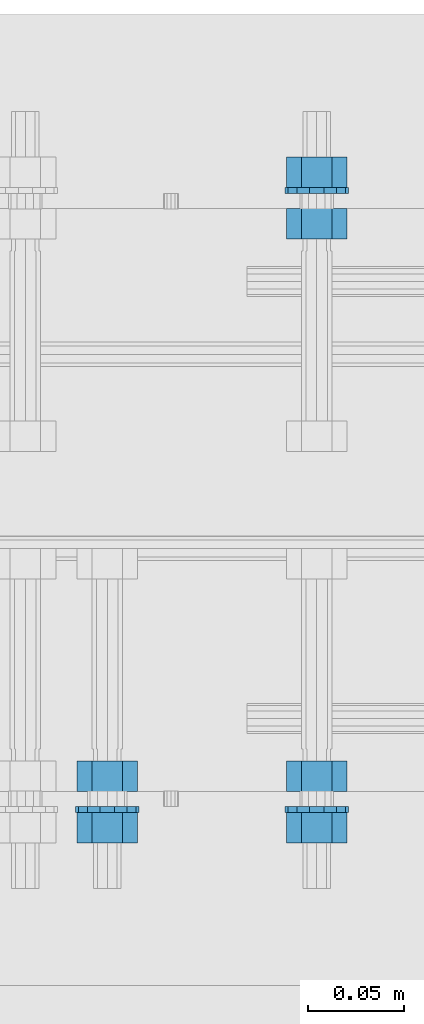
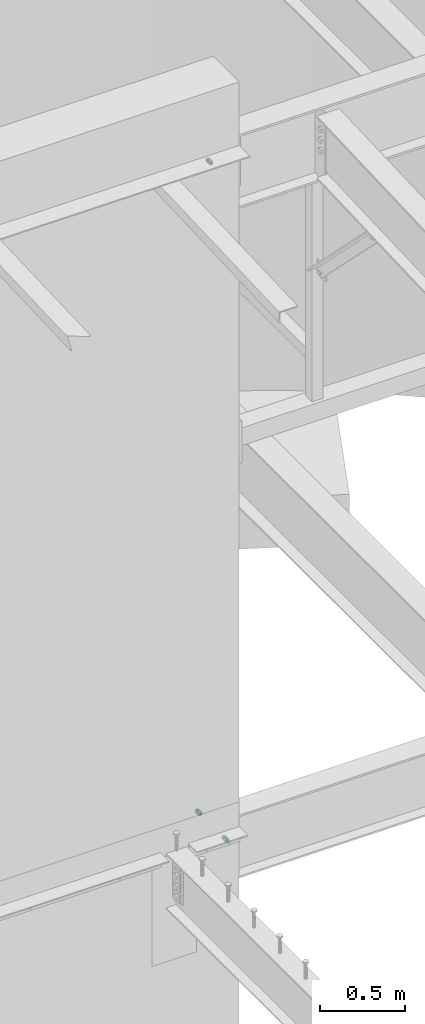
# One storey, part 626 of 975: 9 beams.
"""IFC2X3 building model written with IfcOpenShell, lengths in millimetres."""

from ifc_helpers import new_model, si_unit, frame, origin_with_axes, place, context, subcontext, project, spatial, faceted_brep, material, type_object, element, save


model = new_model("IFC2X3")

# Units and contexts
model_context = context("Model", 3, precision=1e-05, world=origin_with_axes())
body_context = subcontext(model_context, "Body", "Model", "MODEL_VIEW")
ifc_project = project(units=[si_unit("LENGTHUNIT", "METRE", prefix="MILLI"), si_unit("AREAUNIT", "SQUARE_METRE"), si_unit("VOLUMEUNIT", "CUBIC_METRE"), si_unit("MASSUNIT", "GRAM", prefix="KILO"), si_unit("TIMEUNIT", "SECOND"), si_unit("PLANEANGLEUNIT", "RADIAN"), si_unit("SOLIDANGLEUNIT", "STERADIAN"), si_unit("THERMODYNAMICTEMPERATUREUNIT", "DEGREE_CELSIUS"), si_unit("LUMINOUSINTENSITYUNIT", "LUMEN")], contexts=[model_context])

# Site, building, storey
site_placement = place(None, origin_with_axes())
site = spatial("IfcSite", under=ifc_project, at=site_placement, CompositionType="ELEMENT")
building_placement = place(site_placement, origin_with_axes())
building = spatial("IfcBuilding", under=site, at=building_placement, Name="Undefined", CompositionType="ELEMENT")
storey_placement = place(building_placement, origin_with_axes())
storey = spatial("IfcBuildingStorey", under=building, at=storey_placement, Name="Undefined", CompositionType="ELEMENT", Elevation=0.0)

# Beams
ifc_material_1 = material(Name="STEEL/F1554-36")
beam_type_1 = type_object("IfcBeamType", Name="5/8_HEAVY_HEX_NUT", PredefinedType="NOTDEFINED")
beam_1_placement = place(storey_placement, frame((13722.3499940823, 20443.8249990482, 8801.10000023449), z_axis=(0.0, 0.0, 1.0), x_axis=(0.0, 1.0, 0.0)))
element("IfcBeam", 1, at=beam_1_placement, inside=storey, type_object=beam_type_1, material=ifc_material_1, Name="HEADED_ANCHOR_BOLT", ObjectType="5/8_HEAVY_HEX_NUT", context=body_context, shape_type="Brep", body=[
    faceted_brep([(-1.09139364212751e-11, -15.8800001144436, -2.72848410531878e-12), (1.45519152283669e-11, -7.94000005722046, -13.7500000000036), (15.8750000000146, -7.94000005722137, -13.7500000000045), (15.8749999999891, -15.8800001144446, -2.72848410531878e-12), (2.91038304567337e-11, 7.94000005722319, -13.7500000000027), (15.8750000000291, 7.94000005722319, -13.7500000000027), (2.18278728425503e-11, 15.8800001144436, 9.09494701772928e-13), (15.8750000000218, 15.8800001144427, 9.09494701772928e-13), (-7.27595761418343e-12, 7.94000005722046, 13.7500000000027), (15.8749999999927, 7.94000005722046, 13.7500000000027), (-2.18278728425503e-11, -7.94000005722228, 13.7500000000009), (15.8749999999782, -7.94000005722319, 13.7500000000009), (-7.27595761418343e-12, 0.0, 8.72999954223724), (0.0, 3.78780484388062, 7.86545780435881), (15.875, 3.78780484387971, 7.86545780435881), (15.8749999999927, -9.09494701772928e-13, 8.72999954223724), (7.27595761418343e-12, 6.82538848405238, 5.44306568481716), (15.8750000000073, 6.82538848405238, 5.44306568481716), (1.09139364212751e-11, 8.51112022706275, 1.94260765157742), (15.8750000000109, 8.51112022706093, 1.94260765157651), (1.45519152283669e-11, 8.51112022706184, -1.94260765157651), (15.8750000000146, 8.51112022706184, -1.94260765157651), (2.18278728425503e-11, 6.8253884840542, -5.44306568481716), (15.8750000000218, 6.82538848405238, -5.44306568481716), (1.81898940354586e-11, 3.78780484388153, -7.86545780435881), (15.8750000000182, 3.78780484388062, -7.86545780435881), (1.81898940354586e-11, 9.09494701772928e-13, -8.72999954223997), (15.8750000000182, 9.09494701772928e-13, -8.72999954223997), (1.09139364212751e-11, -3.78780484387971, -7.86545780436063), (15.8750000000109, -3.78780484388062, -7.86545780436063), (3.63797880709171e-12, -6.82538848405238, -5.44306568481807), (15.8750000000036, -6.82538848405329, -5.44306568481807), (0.0, -8.51112022706184, -1.94260765157833), (15.875, -8.51112022706184, -1.94260765157833), (-7.27595761418343e-12, -8.51112022706184, 1.9426076515756), (15.8749999999927, -8.51112022706275, 1.9426076515756), (-1.09139364212751e-11, -6.82538848405329, 5.44306568481534), (15.8749999999927, -6.8253884840542, 5.44306568481534), (-7.27595761418343e-12, -3.78780484388062, 7.8654578043579), (15.8749999999927, -3.78780484388153, 7.8654578043579)], [[[0, 1, 2, 3]], [[1, 4, 5, 2]], [[4, 6, 7, 5]], [[6, 8, 9, 7]], [[8, 10, 11, 9]], [[10, 0, 3, 11]], [[12, 13, 14, 15]], [[13, 16, 17, 14]], [[16, 18, 19, 17]], [[18, 20, 21, 19]], [[20, 22, 23, 21]], [[22, 24, 25, 23]], [[24, 26, 27, 25]], [[26, 28, 29, 27]], [[28, 30, 31, 29]], [[30, 32, 33, 31]], [[32, 34, 35, 33]], [[34, 36, 37, 35]], [[36, 38, 39, 37]], [[38, 12, 15, 39]], [[5, 7, 9, 11, 3, 2], [17, 19, 21, 23, 25, 27, 29, 31, 33, 35, 37, 39, 15, 14]], [[10, 8, 6, 4, 1, 0], [38, 36, 34, 32, 30, 28, 26, 24, 22, 20, 18, 16, 13, 12]]]),
])
beam_2_placement = place(storey_placement, frame((13722.3499966058, 20416.8374990479, 8801.10000017628), z_axis=(0.0, 0.0, 1.0), x_axis=(0.0, 1.0, 0.0)))
element("IfcBeam", 2, at=beam_2_placement, inside=storey, type_object=beam_type_1, material=ifc_material_1, Name="HEADED_ANCHOR_BOLT", ObjectType="5/8_HEAVY_HEX_NUT", context=body_context, shape_type="Brep", body=[
    faceted_brep([(-1.09139364212751e-11, -15.8800001144436, -2.72848410531878e-12), (1.45519152283669e-11, -7.94000005722046, -13.7500000000036), (15.8750000000146, -7.94000005722137, -13.7500000000045), (15.8749999999891, -15.8800001144446, -2.72848410531878e-12), (2.91038304567337e-11, 7.94000005722319, -13.7500000000027), (15.8750000000291, 7.94000005722319, -13.7500000000027), (2.18278728425503e-11, 15.8800001144436, 9.09494701772928e-13), (15.8750000000218, 15.8800001144427, 9.09494701772928e-13), (-7.27595761418343e-12, 7.94000005722046, 13.7500000000027), (15.8749999999927, 7.94000005722046, 13.7500000000027), (-2.18278728425503e-11, -7.94000005722228, 13.7500000000009), (15.8749999999782, -7.94000005722319, 13.7500000000009), (-7.27595761418343e-12, 0.0, 8.72999954223724), (0.0, 3.78780484388062, 7.86545780435881), (15.875, 3.78780484387971, 7.86545780435881), (15.8749999999927, -9.09494701772928e-13, 8.72999954223724), (7.27595761418343e-12, 6.82538848405238, 5.44306568481716), (15.8750000000073, 6.82538848405238, 5.44306568481716), (1.09139364212751e-11, 8.51112022706275, 1.94260765157742), (15.8750000000109, 8.51112022706093, 1.94260765157651), (1.45519152283669e-11, 8.51112022706184, -1.94260765157651), (15.8750000000146, 8.51112022706184, -1.94260765157651), (2.18278728425503e-11, 6.8253884840542, -5.44306568481716), (15.8750000000218, 6.82538848405238, -5.44306568481716), (1.81898940354586e-11, 3.78780484388153, -7.86545780435881), (15.8750000000182, 3.78780484388062, -7.86545780435881), (1.81898940354586e-11, 9.09494701772928e-13, -8.72999954223997), (15.8750000000182, 9.09494701772928e-13, -8.72999954223997), (1.09139364212751e-11, -3.78780484387971, -7.86545780436063), (15.8750000000109, -3.78780484388062, -7.86545780436063), (3.63797880709171e-12, -6.82538848405238, -5.44306568481807), (15.8750000000036, -6.82538848405329, -5.44306568481807), (0.0, -8.51112022706184, -1.94260765157833), (15.875, -8.51112022706184, -1.94260765157833), (-7.27595761418343e-12, -8.51112022706184, 1.9426076515756), (15.8749999999927, -8.51112022706275, 1.9426076515756), (-1.09139364212751e-11, -6.82538848405329, 5.44306568481534), (15.8749999999927, -6.8253884840542, 5.44306568481534), (-7.27595761418343e-12, -3.78780484388062, 7.8654578043579), (15.8749999999927, -3.78780484388153, 7.8654578043579)], [[[0, 1, 2, 3]], [[1, 4, 5, 2]], [[4, 6, 7, 5]], [[6, 8, 9, 7]], [[8, 10, 11, 9]], [[10, 0, 3, 11]], [[12, 13, 14, 15]], [[13, 16, 17, 14]], [[16, 18, 19, 17]], [[18, 20, 21, 19]], [[20, 22, 23, 21]], [[22, 24, 25, 23]], [[24, 26, 27, 25]], [[26, 28, 29, 27]], [[28, 30, 31, 29]], [[30, 32, 33, 31]], [[32, 34, 35, 33]], [[34, 36, 37, 35]], [[36, 38, 39, 37]], [[38, 12, 15, 39]], [[5, 7, 9, 11, 3, 2], [17, 19, 21, 23, 25, 27, 29, 31, 33, 35, 37, 39, 15, 14]], [[10, 8, 6, 4, 1, 0], [38, 36, 34, 32, 30, 28, 26, 24, 22, 20, 18, 16, 13, 12]]]),
])
ifc_material_2 = material(Name="STEEL/A36")
beam_3_placement = place(storey_placement, frame((13831.8874969437, 20748.6249997605, 3886.2), z_axis=(0.0, 0.0, -1.0), x_axis=(0.0, -1.0, 0.0)))
element("IfcBeam", 3, at=beam_3_placement, inside=storey, type_object=beam_type_1, material=ifc_material_2, Name="NUT", ObjectType="5/8_HEAVY_HEX_NUT", context=body_context, shape_type="Brep", body=[
    faceted_brep([(-1.09139364212751e-11, -15.8800001144436, -2.72848410531878e-12), (1.45519152283669e-11, -7.94000005722046, -13.7500000000036), (15.8750000000146, -7.94000005722137, -13.7500000000045), (15.8749999999891, -15.8800001144446, -2.72848410531878e-12), (2.91038304567337e-11, 7.94000005722319, -13.7500000000027), (15.8750000000291, 7.94000005722319, -13.7500000000027), (2.18278728425503e-11, 15.8800001144436, 9.09494701772928e-13), (15.8750000000218, 15.8800001144427, 9.09494701772928e-13), (-7.27595761418343e-12, 7.94000005722046, 13.7500000000027), (15.8749999999927, 7.94000005722046, 13.7500000000027), (-2.18278728425503e-11, -7.94000005722228, 13.7500000000009), (15.8749999999782, -7.94000005722319, 13.7500000000009), (-7.27595761418343e-12, 0.0, 8.72999954223724), (0.0, 3.78780484388062, 7.86545780435881), (15.875, 3.78780484387971, 7.86545780435881), (15.8749999999927, -9.09494701772928e-13, 8.72999954223724), (7.27595761418343e-12, 6.82538848405238, 5.44306568481716), (15.8750000000073, 6.82538848405238, 5.44306568481716), (1.09139364212751e-11, 8.51112022706275, 1.94260765157742), (15.8750000000109, 8.51112022706093, 1.94260765157651), (1.45519152283669e-11, 8.51112022706184, -1.94260765157651), (15.8750000000146, 8.51112022706184, -1.94260765157651), (2.18278728425503e-11, 6.8253884840542, -5.44306568481716), (15.8750000000218, 6.82538848405238, -5.44306568481716), (1.81898940354586e-11, 3.78780484388153, -7.86545780435881), (15.8750000000182, 3.78780484388062, -7.86545780435881), (1.81898940354586e-11, 9.09494701772928e-13, -8.72999954223997), (15.8750000000182, 9.09494701772928e-13, -8.72999954223997), (1.09139364212751e-11, -3.78780484387971, -7.86545780436063), (15.8750000000109, -3.78780484388062, -7.86545780436063), (3.63797880709171e-12, -6.82538848405238, -5.44306568481807), (15.8750000000036, -6.82538848405329, -5.44306568481807), (0.0, -8.51112022706184, -1.94260765157833), (15.875, -8.51112022706184, -1.94260765157833), (-7.27595761418343e-12, -8.51112022706184, 1.9426076515756), (15.8749999999927, -8.51112022706275, 1.9426076515756), (-1.09139364212751e-11, -6.82538848405329, 5.44306568481534), (15.8749999999927, -6.8253884840542, 5.44306568481534), (-7.27595761418343e-12, -3.78780484388062, 7.8654578043579), (15.8749999999927, -3.78780484388153, 7.8654578043579)], [[[0, 1, 2, 3]], [[1, 4, 5, 2]], [[4, 6, 7, 5]], [[6, 8, 9, 7]], [[8, 10, 11, 9]], [[10, 0, 3, 11]], [[12, 13, 14, 15]], [[13, 16, 17, 14]], [[16, 18, 19, 17]], [[18, 20, 21, 19]], [[20, 22, 23, 21]], [[22, 24, 25, 23]], [[24, 26, 27, 25]], [[26, 28, 29, 27]], [[28, 30, 31, 29]], [[30, 32, 33, 31]], [[32, 34, 35, 33]], [[34, 36, 37, 35]], [[36, 38, 39, 37]], [[38, 12, 15, 39]], [[5, 7, 9, 11, 3, 2], [17, 19, 21, 23, 25, 27, 29, 31, 33, 35, 37, 39, 15, 14]], [[10, 8, 6, 4, 1, 0], [38, 36, 34, 32, 30, 28, 26, 24, 22, 20, 18, 16, 13, 12]]]),
])
beam_4_placement = place(storey_placement, frame((13831.8874969437, 20443.8250002493, 3886.2), z_axis=(0.0, 0.0, 1.0), x_axis=(0.0, 1.0, 0.0)))
element("IfcBeam", 4, at=beam_4_placement, inside=storey, type_object=beam_type_1, material=ifc_material_2, Name="NUT", ObjectType="5/8_HEAVY_HEX_NUT", context=body_context, shape_type="Brep", body=[
    faceted_brep([(-1.09139364212751e-11, -15.8800001144436, -2.72848410531878e-12), (1.45519152283669e-11, -7.94000005722046, -13.7500000000036), (15.8750000000146, -7.94000005722137, -13.7500000000045), (15.8749999999891, -15.8800001144446, -2.72848410531878e-12), (2.91038304567337e-11, 7.94000005722319, -13.7500000000027), (15.8750000000291, 7.94000005722319, -13.7500000000027), (2.18278728425503e-11, 15.8800001144436, 9.09494701772928e-13), (15.8750000000218, 15.8800001144427, 9.09494701772928e-13), (-7.27595761418343e-12, 7.94000005722046, 13.7500000000027), (15.8749999999927, 7.94000005722046, 13.7500000000027), (-2.18278728425503e-11, -7.94000005722228, 13.7500000000009), (15.8749999999782, -7.94000005722319, 13.7500000000009), (-7.27595761418343e-12, 0.0, 8.72999954223724), (0.0, 3.78780484388062, 7.86545780435881), (15.875, 3.78780484387971, 7.86545780435881), (15.8749999999927, -9.09494701772928e-13, 8.72999954223724), (7.27595761418343e-12, 6.82538848405238, 5.44306568481716), (15.8750000000073, 6.82538848405238, 5.44306568481716), (1.09139364212751e-11, 8.51112022706275, 1.94260765157742), (15.8750000000109, 8.51112022706093, 1.94260765157651), (1.45519152283669e-11, 8.51112022706184, -1.94260765157651), (15.8750000000146, 8.51112022706184, -1.94260765157651), (2.18278728425503e-11, 6.8253884840542, -5.44306568481716), (15.8750000000218, 6.82538848405238, -5.44306568481716), (1.81898940354586e-11, 3.78780484388153, -7.86545780435881), (15.8750000000182, 3.78780484388062, -7.86545780435881), (1.81898940354586e-11, 9.09494701772928e-13, -8.72999954223997), (15.8750000000182, 9.09494701772928e-13, -8.72999954223997), (1.09139364212751e-11, -3.78780484387971, -7.86545780436063), (15.8750000000109, -3.78780484388062, -7.86545780436063), (3.63797880709171e-12, -6.82538848405238, -5.44306568481807), (15.8750000000036, -6.82538848405329, -5.44306568481807), (0.0, -8.51112022706184, -1.94260765157833), (15.875, -8.51112022706184, -1.94260765157833), (-7.27595761418343e-12, -8.51112022706184, 1.9426076515756), (15.8749999999927, -8.51112022706275, 1.9426076515756), (-1.09139364212751e-11, -6.82538848405329, 5.44306568481534), (15.8749999999927, -6.8253884840542, 5.44306568481534), (-7.27595761418343e-12, -3.78780484388062, 7.8654578043579), (15.8749999999927, -3.78780484388153, 7.8654578043579)], [[[0, 1, 2, 3]], [[1, 4, 5, 2]], [[4, 6, 7, 5]], [[6, 8, 9, 7]], [[8, 10, 11, 9]], [[10, 0, 3, 11]], [[12, 13, 14, 15]], [[13, 16, 17, 14]], [[16, 18, 19, 17]], [[18, 20, 21, 19]], [[20, 22, 23, 21]], [[22, 24, 25, 23]], [[24, 26, 27, 25]], [[26, 28, 29, 27]], [[28, 30, 31, 29]], [[30, 32, 33, 31]], [[32, 34, 35, 33]], [[34, 36, 37, 35]], [[36, 38, 39, 37]], [[38, 12, 15, 39]], [[5, 7, 9, 11, 3, 2], [17, 19, 21, 23, 25, 27, 29, 31, 33, 35, 37, 39, 15, 14]], [[10, 8, 6, 4, 1, 0], [38, 36, 34, 32, 30, 28, 26, 24, 22, 20, 18, 16, 13, 12]]]),
])
beam_5_placement = place(storey_placement, frame((13831.8874969706, 20775.6124997508, 3886.2), z_axis=(0.0, 0.0, -1.0), x_axis=(0.0, -1.0, 0.0)))
element("IfcBeam", 5, at=beam_5_placement, inside=storey, type_object=beam_type_1, material=ifc_material_2, Name="NUT", ObjectType="5/8_HEAVY_HEX_NUT", context=body_context, shape_type="Brep", body=[
    faceted_brep([(-1.09139364212751e-11, -15.8800001144436, -2.72848410531878e-12), (1.45519152283669e-11, -7.94000005722046, -13.7500000000036), (15.8750000000146, -7.94000005722137, -13.7500000000045), (15.8749999999891, -15.8800001144446, -2.72848410531878e-12), (2.91038304567337e-11, 7.94000005722319, -13.7500000000027), (15.8750000000291, 7.94000005722319, -13.7500000000027), (2.18278728425503e-11, 15.8800001144436, 9.09494701772928e-13), (15.8750000000218, 15.8800001144427, 9.09494701772928e-13), (-7.27595761418343e-12, 7.94000005722046, 13.7500000000027), (15.8749999999927, 7.94000005722046, 13.7500000000027), (-2.18278728425503e-11, -7.94000005722228, 13.7500000000009), (15.8749999999782, -7.94000005722319, 13.7500000000009), (-7.27595761418343e-12, 0.0, 8.72999954223724), (0.0, 3.78780484388062, 7.86545780435881), (15.875, 3.78780484387971, 7.86545780435881), (15.8749999999927, -9.09494701772928e-13, 8.72999954223724), (7.27595761418343e-12, 6.82538848405238, 5.44306568481716), (15.8750000000073, 6.82538848405238, 5.44306568481716), (1.09139364212751e-11, 8.51112022706275, 1.94260765157742), (15.8750000000109, 8.51112022706093, 1.94260765157651), (1.45519152283669e-11, 8.51112022706184, -1.94260765157651), (15.8750000000146, 8.51112022706184, -1.94260765157651), (2.18278728425503e-11, 6.8253884840542, -5.44306568481716), (15.8750000000218, 6.82538848405238, -5.44306568481716), (1.81898940354586e-11, 3.78780484388153, -7.86545780435881), (15.8750000000182, 3.78780484388062, -7.86545780435881), (1.81898940354586e-11, 9.09494701772928e-13, -8.72999954223997), (15.8750000000182, 9.09494701772928e-13, -8.72999954223997), (1.09139364212751e-11, -3.78780484387971, -7.86545780436063), (15.8750000000109, -3.78780484388062, -7.86545780436063), (3.63797880709171e-12, -6.82538848405238, -5.44306568481807), (15.8750000000036, -6.82538848405329, -5.44306568481807), (0.0, -8.51112022706184, -1.94260765157833), (15.875, -8.51112022706184, -1.94260765157833), (-7.27595761418343e-12, -8.51112022706184, 1.9426076515756), (15.8749999999927, -8.51112022706275, 1.9426076515756), (-1.09139364212751e-11, -6.82538848405329, 5.44306568481534), (15.8749999999927, -6.8253884840542, 5.44306568481534), (-7.27595761418343e-12, -3.78780484388062, 7.8654578043579), (15.8749999999927, -3.78780484388153, 7.8654578043579)], [[[0, 1, 2, 3]], [[1, 4, 5, 2]], [[4, 6, 7, 5]], [[6, 8, 9, 7]], [[8, 10, 11, 9]], [[10, 0, 3, 11]], [[12, 13, 14, 15]], [[13, 16, 17, 14]], [[16, 18, 19, 17]], [[18, 20, 21, 19]], [[20, 22, 23, 21]], [[22, 24, 25, 23]], [[24, 26, 27, 25]], [[26, 28, 29, 27]], [[28, 30, 31, 29]], [[30, 32, 33, 31]], [[32, 34, 35, 33]], [[34, 36, 37, 35]], [[36, 38, 39, 37]], [[38, 12, 15, 39]], [[5, 7, 9, 11, 3, 2], [17, 19, 21, 23, 25, 27, 29, 31, 33, 35, 37, 39, 15, 14]], [[10, 8, 6, 4, 1, 0], [38, 36, 34, 32, 30, 28, 26, 24, 22, 20, 18, 16, 13, 12]]]),
])
beam_6_placement = place(storey_placement, frame((13831.8874969706, 20416.8375002493, 3886.2), z_axis=(0.0, 0.0, 1.0), x_axis=(0.0, 1.0, 0.0)))
element("IfcBeam", 6, at=beam_6_placement, inside=storey, type_object=beam_type_1, material=ifc_material_2, Name="NUT", ObjectType="5/8_HEAVY_HEX_NUT", context=body_context, shape_type="Brep", body=[
    faceted_brep([(-1.09139364212751e-11, -15.8800001144436, -2.72848410531878e-12), (1.45519152283669e-11, -7.94000005722046, -13.7500000000036), (15.8750000000146, -7.94000005722137, -13.7500000000045), (15.8749999999891, -15.8800001144446, -2.72848410531878e-12), (2.91038304567337e-11, 7.94000005722319, -13.7500000000027), (15.8750000000291, 7.94000005722319, -13.7500000000027), (2.18278728425503e-11, 15.8800001144436, 9.09494701772928e-13), (15.8750000000218, 15.8800001144427, 9.09494701772928e-13), (-7.27595761418343e-12, 7.94000005722046, 13.7500000000027), (15.8749999999927, 7.94000005722046, 13.7500000000027), (-2.18278728425503e-11, -7.94000005722228, 13.7500000000009), (15.8749999999782, -7.94000005722319, 13.7500000000009), (-7.27595761418343e-12, 0.0, 8.72999954223724), (0.0, 3.78780484388062, 7.86545780435881), (15.875, 3.78780484387971, 7.86545780435881), (15.8749999999927, -9.09494701772928e-13, 8.72999954223724), (7.27595761418343e-12, 6.82538848405238, 5.44306568481716), (15.8750000000073, 6.82538848405238, 5.44306568481716), (1.09139364212751e-11, 8.51112022706275, 1.94260765157742), (15.8750000000109, 8.51112022706093, 1.94260765157651), (1.45519152283669e-11, 8.51112022706184, -1.94260765157651), (15.8750000000146, 8.51112022706184, -1.94260765157651), (2.18278728425503e-11, 6.8253884840542, -5.44306568481716), (15.8750000000218, 6.82538848405238, -5.44306568481716), (1.81898940354586e-11, 3.78780484388153, -7.86545780435881), (15.8750000000182, 3.78780484388062, -7.86545780435881), (1.81898940354586e-11, 9.09494701772928e-13, -8.72999954223997), (15.8750000000182, 9.09494701772928e-13, -8.72999954223997), (1.09139364212751e-11, -3.78780484387971, -7.86545780436063), (15.8750000000109, -3.78780484388062, -7.86545780436063), (3.63797880709171e-12, -6.82538848405238, -5.44306568481807), (15.8750000000036, -6.82538848405329, -5.44306568481807), (0.0, -8.51112022706184, -1.94260765157833), (15.875, -8.51112022706184, -1.94260765157833), (-7.27595761418343e-12, -8.51112022706184, 1.9426076515756), (15.8749999999927, -8.51112022706275, 1.9426076515756), (-1.09139364212751e-11, -6.82538848405329, 5.44306568481534), (15.8749999999927, -6.8253884840542, 5.44306568481534), (-7.27595761418343e-12, -3.78780484388062, 7.8654578043579), (15.8749999999927, -3.78780484388153, 7.8654578043579)], [[[0, 1, 2, 3]], [[1, 4, 5, 2]], [[4, 6, 7, 5]], [[6, 8, 9, 7]], [[8, 10, 11, 9]], [[10, 0, 3, 11]], [[12, 13, 14, 15]], [[13, 16, 17, 14]], [[16, 18, 19, 17]], [[18, 20, 21, 19]], [[20, 22, 23, 21]], [[22, 24, 25, 23]], [[24, 26, 27, 25]], [[26, 28, 29, 27]], [[28, 30, 31, 29]], [[30, 32, 33, 31]], [[32, 34, 35, 33]], [[34, 36, 37, 35]], [[36, 38, 39, 37]], [[38, 12, 15, 39]], [[5, 7, 9, 11, 3, 2], [17, 19, 21, 23, 25, 27, 29, 31, 33, 35, 37, 39, 15, 14]], [[10, 8, 6, 4, 1, 0], [38, 36, 34, 32, 30, 28, 26, 24, 22, 20, 18, 16, 13, 12]]]),
])
beam_type_2 = type_object("IfcBeamType", Name="5/8_WASHER", PredefinedType="NOTDEFINED")
beam_7_placement = place(storey_placement, frame((13722.3499950685, 20432.7124990477, 8801.10000026254), z_axis=(0.0, 0.0, 1.0), x_axis=(0.0, 1.0, 0.0)))
element("IfcBeam", 7, at=beam_7_placement, inside=storey, type_object=beam_type_2, material=ifc_material_1, Name="HEADED_ANCHOR_BOLT", ObjectType="5/8_WASHER", context=body_context, shape_type="Brep", body=[
    faceted_brep([(1.09139364212751e-11, -16.670000076293, -2.72848410531878e-12), (2.18278728425503e-11, -15.0191510966704, -7.23284196419536), (3.1750000000211, -15.0191510966711, -7.23284196419627), (3.17500000001019, -16.6700000762937, -1.81898940354586e-12), (2.91038304567337e-11, -10.3935750445523, -13.0331308723944), (3.17500000002838, -10.3935750445526, -13.0331308723953), (2.91038304567337e-11, -3.70942398602756, -16.2520483704566), (3.17500000002838, -3.70942398602779, -16.2520483704566), (2.5465851649642e-11, 3.70942398602961, -16.2520483704557), (3.17500000002474, 3.70942398602961, -16.2520483704566), (1.45519152283669e-11, 10.3935750445542, -13.0331308723935), (3.17500000001382, 10.3935750445537, -13.0331308723944), (0.0, 15.0191510966717, -7.23284196419354), (3.17499999999927, 15.0191510966713, -7.23284196419354), (-7.27595761418343e-12, 16.6700000762933, 0.0), (3.174999999992, 16.6700000762928, -9.09494701772928e-13), (-1.81898940354586e-11, 15.0191510966706, 7.23284196419354), (3.17499999998108, 15.0191510966704, 7.23284196419354), (-2.5465851649642e-11, 10.3935750445519, 13.0331308723926), (3.17499999997381, 10.3935750445517, 13.0331308723926), (-2.5465851649642e-11, 3.70942398602733, 16.2520483704538), (3.17499999997381, 3.7094239860271, 16.2520483704529), (-2.18278728425503e-11, -3.70942398602983, 16.2520483704529), (3.17499999997744, -3.70942398603006, 16.2520483704538), (-1.09139364212751e-11, -10.3935750445542, 13.0331308723908), (3.17499999998836, -10.3935750445544, 13.0331308723908), (0.0, -15.0191510966717, 7.23284196419172), (3.17499999999927, -15.019151096672, 7.23284196419081), (-7.27595761418343e-12, 0.0, 8.72999954223724), (0.0, 3.78780484388062, 7.86545780435881), (3.17499999998472, 3.78780484387903, 7.86545780435699), (3.17499999998836, -9.09494701772928e-13, 8.72999954223542), (7.27595761418343e-12, 6.82538848405238, 5.44306568481716), (3.17499999998836, 6.82538848405102, 5.44306568481534), (1.09139364212751e-11, 8.51112022706275, 1.94260765157742), (3.174999999992, 8.51112022705979, 1.94260765157651), (1.45519152283669e-11, 8.51112022706184, -1.94260765157651), (3.17499999999563, 8.51112022706025, -1.94260765157742), (2.18278728425503e-11, 6.8253884840542, -5.44306568481716), (3.17500000000655, 6.8253884840517, -5.44306568481807), (1.81898940354586e-11, 3.78780484388153, -7.86545780435881), (3.17500000001019, 3.78780484388017, -7.86545780435972), (1.81898940354586e-11, 9.09494701772928e-13, -8.72999954223997), (3.17500000001382, 6.82121026329696e-13, -8.72999954223997), (1.09139364212751e-11, -3.78780484387971, -7.86545780436063), (3.17500000001382, -3.78780484387994, -7.86545780436063), (3.63797880709171e-12, -6.82538848405238, -5.44306568481807), (3.17500000001019, -6.82538848405147, -5.44306568481898), (0.0, -8.51112022706184, -1.94260765157833), (3.17500000001019, -8.5111202270607, -1.94260765157924), (-7.27595761418343e-12, -8.51112022706184, 1.9426076515756), (3.17500000000291, -8.51112022706093, 1.94260765157469), (-1.09139364212751e-11, -6.82538848405329, 5.44306568481534), (3.17499999999563, -6.82538848405238, 5.44306568481534), (-7.27595761418343e-12, -3.78780484388062, 7.8654578043579), (3.174999999992, -3.78780484388085, 7.86545780435699)], [[[0, 1, 2, 3]], [[1, 4, 5, 2]], [[4, 6, 7, 5]], [[6, 8, 9, 7]], [[8, 10, 11, 9]], [[10, 12, 13, 11]], [[12, 14, 15, 13]], [[14, 16, 17, 15]], [[16, 18, 19, 17]], [[18, 20, 21, 19]], [[20, 22, 23, 21]], [[22, 24, 25, 23]], [[24, 26, 27, 25]], [[26, 0, 3, 27]], [[28, 29, 30, 31]], [[29, 32, 33, 30]], [[32, 34, 35, 33]], [[34, 36, 37, 35]], [[36, 38, 39, 37]], [[38, 40, 41, 39]], [[40, 42, 43, 41]], [[42, 44, 45, 43]], [[44, 46, 47, 45]], [[46, 48, 49, 47]], [[48, 50, 51, 49]], [[50, 52, 53, 51]], [[52, 54, 55, 53]], [[54, 28, 31, 55]], [[5, 7, 9, 11, 13, 15, 17, 19, 21, 23, 25, 27, 3, 2], [33, 35, 37, 39, 41, 43, 45, 47, 49, 51, 53, 55, 31, 30]], [[26, 24, 22, 20, 18, 16, 14, 12, 10, 8, 6, 4, 1, 0], [54, 52, 50, 48, 46, 44, 42, 40, 38, 36, 34, 32, 29, 28]]]),
])
beam_8_placement = place(storey_placement, frame((13831.8874969547, 20759.7374997508, 3886.2), z_axis=(0.0, 0.0, -1.0), x_axis=(0.0, -1.0, 0.0)))
element("IfcBeam", 8, at=beam_8_placement, inside=storey, type_object=beam_type_2, material=ifc_material_2, Name="WASHER", ObjectType="5/8_WASHER", context=body_context, shape_type="Brep", body=[
    faceted_brep([(1.09139364212751e-11, -16.670000076293, -2.72848410531878e-12), (2.18278728425503e-11, -15.0191510966704, -7.23284196419536), (3.1750000000211, -15.0191510966711, -7.23284196419627), (3.17500000001019, -16.6700000762937, -1.81898940354586e-12), (2.91038304567337e-11, -10.3935750445523, -13.0331308723944), (3.17500000002838, -10.3935750445526, -13.0331308723953), (2.91038304567337e-11, -3.70942398602756, -16.2520483704566), (3.17500000002838, -3.70942398602779, -16.2520483704566), (2.5465851649642e-11, 3.70942398602961, -16.2520483704557), (3.17500000002474, 3.70942398602961, -16.2520483704566), (1.45519152283669e-11, 10.3935750445542, -13.0331308723935), (3.17500000001382, 10.3935750445537, -13.0331308723944), (0.0, 15.0191510966717, -7.23284196419354), (3.17499999999927, 15.0191510966713, -7.23284196419354), (-7.27595761418343e-12, 16.6700000762933, 0.0), (3.174999999992, 16.6700000762928, -9.09494701772928e-13), (-1.81898940354586e-11, 15.0191510966706, 7.23284196419354), (3.17499999998108, 15.0191510966704, 7.23284196419354), (-2.5465851649642e-11, 10.3935750445519, 13.0331308723926), (3.17499999997381, 10.3935750445517, 13.0331308723926), (-2.5465851649642e-11, 3.70942398602733, 16.2520483704538), (3.17499999997381, 3.7094239860271, 16.2520483704529), (-2.18278728425503e-11, -3.70942398602983, 16.2520483704529), (3.17499999997744, -3.70942398603006, 16.2520483704538), (-1.09139364212751e-11, -10.3935750445542, 13.0331308723908), (3.17499999998836, -10.3935750445544, 13.0331308723908), (0.0, -15.0191510966717, 7.23284196419172), (3.17499999999927, -15.019151096672, 7.23284196419081), (-7.27595761418343e-12, 0.0, 8.72999954223724), (0.0, 3.78780484388062, 7.86545780435881), (3.17499999998472, 3.78780484387903, 7.86545780435699), (3.17499999998836, -9.09494701772928e-13, 8.72999954223542), (7.27595761418343e-12, 6.82538848405238, 5.44306568481716), (3.17499999998836, 6.82538848405102, 5.44306568481534), (1.09139364212751e-11, 8.51112022706275, 1.94260765157742), (3.174999999992, 8.51112022705979, 1.94260765157651), (1.45519152283669e-11, 8.51112022706184, -1.94260765157651), (3.17499999999563, 8.51112022706025, -1.94260765157742), (2.18278728425503e-11, 6.8253884840542, -5.44306568481716), (3.17500000000655, 6.8253884840517, -5.44306568481807), (1.81898940354586e-11, 3.78780484388153, -7.86545780435881), (3.17500000001019, 3.78780484388017, -7.86545780435972), (1.81898940354586e-11, 9.09494701772928e-13, -8.72999954223997), (3.17500000001382, 6.82121026329696e-13, -8.72999954223997), (1.09139364212751e-11, -3.78780484387971, -7.86545780436063), (3.17500000001382, -3.78780484387994, -7.86545780436063), (3.63797880709171e-12, -6.82538848405238, -5.44306568481807), (3.17500000001019, -6.82538848405147, -5.44306568481898), (0.0, -8.51112022706184, -1.94260765157833), (3.17500000001019, -8.5111202270607, -1.94260765157924), (-7.27595761418343e-12, -8.51112022706184, 1.9426076515756), (3.17500000000291, -8.51112022706093, 1.94260765157469), (-1.09139364212751e-11, -6.82538848405329, 5.44306568481534), (3.17499999999563, -6.82538848405238, 5.44306568481534), (-7.27595761418343e-12, -3.78780484388062, 7.8654578043579), (3.174999999992, -3.78780484388085, 7.86545780435699)], [[[0, 1, 2, 3]], [[1, 4, 5, 2]], [[4, 6, 7, 5]], [[6, 8, 9, 7]], [[8, 10, 11, 9]], [[10, 12, 13, 11]], [[12, 14, 15, 13]], [[14, 16, 17, 15]], [[16, 18, 19, 17]], [[18, 20, 21, 19]], [[20, 22, 23, 21]], [[22, 24, 25, 23]], [[24, 26, 27, 25]], [[26, 0, 3, 27]], [[28, 29, 30, 31]], [[29, 32, 33, 30]], [[32, 34, 35, 33]], [[34, 36, 37, 35]], [[36, 38, 39, 37]], [[38, 40, 41, 39]], [[40, 42, 43, 41]], [[42, 44, 45, 43]], [[44, 46, 47, 45]], [[46, 48, 49, 47]], [[48, 50, 51, 49]], [[50, 52, 53, 51]], [[52, 54, 55, 53]], [[54, 28, 31, 55]], [[5, 7, 9, 11, 13, 15, 17, 19, 21, 23, 25, 27, 3, 2], [33, 35, 37, 39, 41, 43, 45, 47, 49, 51, 53, 55, 31, 30]], [[26, 24, 22, 20, 18, 16, 14, 12, 10, 8, 6, 4, 1, 0], [54, 52, 50, 48, 46, 44, 42, 40, 38, 36, 34, 32, 29, 28]]]),
])
beam_9_placement = place(storey_placement, frame((13831.8874969547, 20432.7125002493, 3886.2), z_axis=(0.0, 0.0, 1.0), x_axis=(0.0, 1.0, 0.0)))
element("IfcBeam", 9, at=beam_9_placement, inside=storey, type_object=beam_type_2, material=ifc_material_2, Name="WASHER", ObjectType="5/8_WASHER", context=body_context, shape_type="Brep", body=[
    faceted_brep([(1.09139364212751e-11, -16.670000076293, -2.72848410531878e-12), (2.18278728425503e-11, -15.0191510966704, -7.23284196419536), (3.1750000000211, -15.0191510966711, -7.23284196419627), (3.17500000001019, -16.6700000762937, -1.81898940354586e-12), (2.91038304567337e-11, -10.3935750445523, -13.0331308723944), (3.17500000002838, -10.3935750445526, -13.0331308723953), (2.91038304567337e-11, -3.70942398602756, -16.2520483704566), (3.17500000002838, -3.70942398602779, -16.2520483704566), (2.5465851649642e-11, 3.70942398602961, -16.2520483704557), (3.17500000002474, 3.70942398602961, -16.2520483704566), (1.45519152283669e-11, 10.3935750445542, -13.0331308723935), (3.17500000001382, 10.3935750445537, -13.0331308723944), (0.0, 15.0191510966717, -7.23284196419354), (3.17499999999927, 15.0191510966713, -7.23284196419354), (-7.27595761418343e-12, 16.6700000762933, 0.0), (3.174999999992, 16.6700000762928, -9.09494701772928e-13), (-1.81898940354586e-11, 15.0191510966706, 7.23284196419354), (3.17499999998108, 15.0191510966704, 7.23284196419354), (-2.5465851649642e-11, 10.3935750445519, 13.0331308723926), (3.17499999997381, 10.3935750445517, 13.0331308723926), (-2.5465851649642e-11, 3.70942398602733, 16.2520483704538), (3.17499999997381, 3.7094239860271, 16.2520483704529), (-2.18278728425503e-11, -3.70942398602983, 16.2520483704529), (3.17499999997744, -3.70942398603006, 16.2520483704538), (-1.09139364212751e-11, -10.3935750445542, 13.0331308723908), (3.17499999998836, -10.3935750445544, 13.0331308723908), (0.0, -15.0191510966717, 7.23284196419172), (3.17499999999927, -15.019151096672, 7.23284196419081), (-7.27595761418343e-12, 0.0, 8.72999954223724), (0.0, 3.78780484388062, 7.86545780435881), (3.17499999998472, 3.78780484387903, 7.86545780435699), (3.17499999998836, -9.09494701772928e-13, 8.72999954223542), (7.27595761418343e-12, 6.82538848405238, 5.44306568481716), (3.17499999998836, 6.82538848405102, 5.44306568481534), (1.09139364212751e-11, 8.51112022706275, 1.94260765157742), (3.174999999992, 8.51112022705979, 1.94260765157651), (1.45519152283669e-11, 8.51112022706184, -1.94260765157651), (3.17499999999563, 8.51112022706025, -1.94260765157742), (2.18278728425503e-11, 6.8253884840542, -5.44306568481716), (3.17500000000655, 6.8253884840517, -5.44306568481807), (1.81898940354586e-11, 3.78780484388153, -7.86545780435881), (3.17500000001019, 3.78780484388017, -7.86545780435972), (1.81898940354586e-11, 9.09494701772928e-13, -8.72999954223997), (3.17500000001382, 6.82121026329696e-13, -8.72999954223997), (1.09139364212751e-11, -3.78780484387971, -7.86545780436063), (3.17500000001382, -3.78780484387994, -7.86545780436063), (3.63797880709171e-12, -6.82538848405238, -5.44306568481807), (3.17500000001019, -6.82538848405147, -5.44306568481898), (0.0, -8.51112022706184, -1.94260765157833), (3.17500000001019, -8.5111202270607, -1.94260765157924), (-7.27595761418343e-12, -8.51112022706184, 1.9426076515756), (3.17500000000291, -8.51112022706093, 1.94260765157469), (-1.09139364212751e-11, -6.82538848405329, 5.44306568481534), (3.17499999999563, -6.82538848405238, 5.44306568481534), (-7.27595761418343e-12, -3.78780484388062, 7.8654578043579), (3.174999999992, -3.78780484388085, 7.86545780435699)], [[[0, 1, 2, 3]], [[1, 4, 5, 2]], [[4, 6, 7, 5]], [[6, 8, 9, 7]], [[8, 10, 11, 9]], [[10, 12, 13, 11]], [[12, 14, 15, 13]], [[14, 16, 17, 15]], [[16, 18, 19, 17]], [[18, 20, 21, 19]], [[20, 22, 23, 21]], [[22, 24, 25, 23]], [[24, 26, 27, 25]], [[26, 0, 3, 27]], [[28, 29, 30, 31]], [[29, 32, 33, 30]], [[32, 34, 35, 33]], [[34, 36, 37, 35]], [[36, 38, 39, 37]], [[38, 40, 41, 39]], [[40, 42, 43, 41]], [[42, 44, 45, 43]], [[44, 46, 47, 45]], [[46, 48, 49, 47]], [[48, 50, 51, 49]], [[50, 52, 53, 51]], [[52, 54, 55, 53]], [[54, 28, 31, 55]], [[5, 7, 9, 11, 13, 15, 17, 19, 21, 23, 25, 27, 3, 2], [33, 35, 37, 39, 41, 43, 45, 47, 49, 51, 53, 55, 31, 30]], [[26, 24, 22, 20, 18, 16, 14, 12, 10, 8, 6, 4, 1, 0], [54, 52, 50, 48, 46, 44, 42, 40, 38, 36, 34, 32, 29, 28]]]),
])

save(model, "model.ifc")
